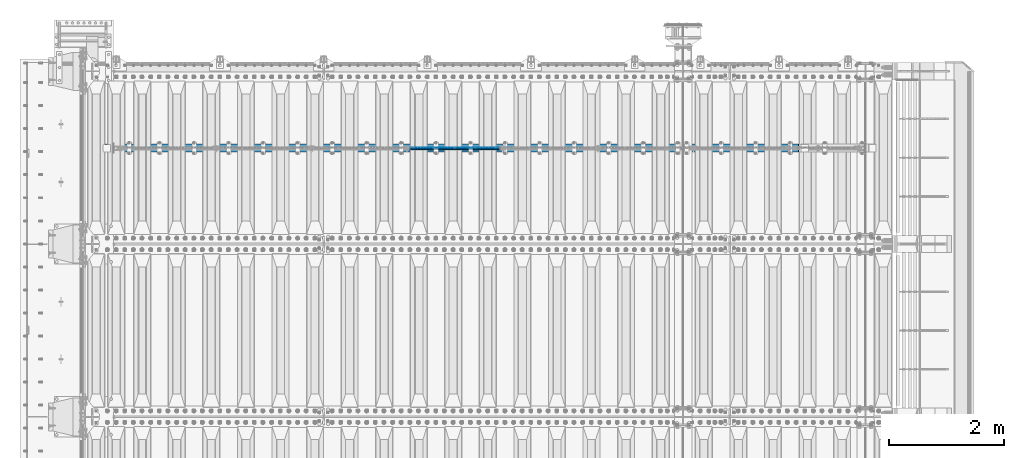
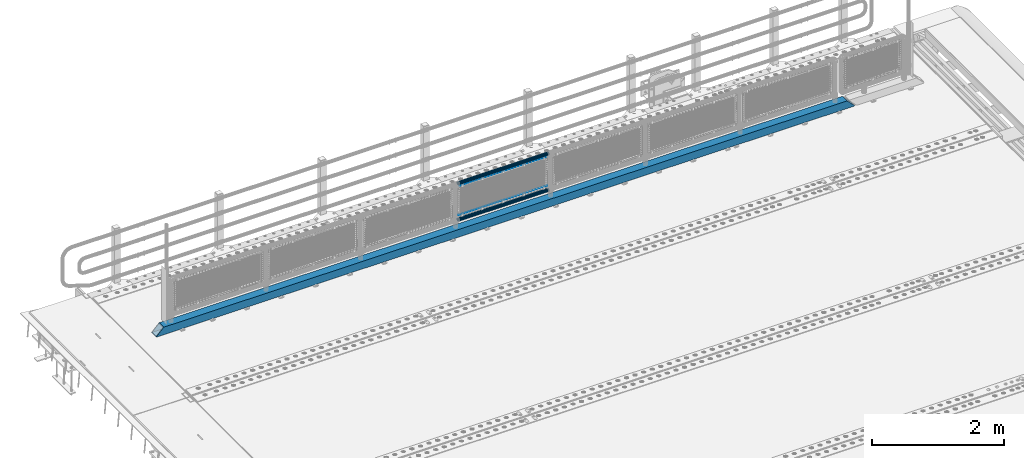
# One storey, part 118 of 240: 5 beams.
"""IFC2X3 building model written with IfcOpenShell, lengths in millimetres."""

from ifc_helpers import new_model, si_unit, frame, origin_with_axes, place, context, subcontext, project, spatial, faceted_brep, material, type_object, element, save


model = new_model("IFC2X3")

# Units and contexts
model_context = context("Model", 3, precision=1e-05, world=origin_with_axes())
body_context = subcontext(model_context, "Body", "Model", "MODEL_VIEW")
ifc_project = project(units=[si_unit("LENGTHUNIT", "METRE", prefix="MILLI"), si_unit("AREAUNIT", "SQUARE_METRE"), si_unit("VOLUMEUNIT", "CUBIC_METRE"), si_unit("MASSUNIT", "GRAM", prefix="KILO"), si_unit("TIMEUNIT", "SECOND"), si_unit("PLANEANGLEUNIT", "RADIAN"), si_unit("SOLIDANGLEUNIT", "STERADIAN"), si_unit("THERMODYNAMICTEMPERATUREUNIT", "DEGREE_CELSIUS"), si_unit("LUMINOUSINTENSITYUNIT", "LUMEN")], contexts=[model_context])

# Site, building, storey
site_placement = place(None, origin_with_axes())
site = spatial("IfcSite", under=ifc_project, at=site_placement, CompositionType="ELEMENT")
building_placement = place(site_placement, origin_with_axes())
building = spatial("IfcBuilding", under=site, at=building_placement, Name="Standard", CompositionType="ELEMENT")
storey_placement = place(building_placement, origin_with_axes())
storey = spatial("IfcBuildingStorey", under=building, at=storey_placement, Name="Undefined", CompositionType="ELEMENT", Elevation=0.0)

# Beams
ifc_material_1 = material(Name="Misc_Undefined")
beam_type_1 = type_object("IfcBeamType", Name="D3", PredefinedType="NOTDEFINED")
beam_1_placement = place(storey_placement, frame((48100.0, 34670.5, 378.02), z_axis=(0.0, 0.0, 1.0), x_axis=(1.0, 0.0, 0.0)))
element("IfcBeam", 1, at=beam_1_placement, inside=storey, type_object=beam_type_1, material=ifc_material_1, ObjectType="D3", context=body_context, shape_type="Brep", body=[
    faceted_brep([(-7.27595761418343e-12, -1.49999999999272, 0.0), (-7.27595761418343e-12, -0.749999999992724, -1.29903810567669), (1548.0, -0.75, -1.29903810567669), (1548.0, -1.5, 0.0), (0.0, 0.750000000007276, -1.29903810567669), (1548.0, 0.75, -1.29903810567669), (0.0, 1.50000000000728, 0.0), (1548.0, 1.5, 0.0), (0.0, 0.750000000007276, 1.29903810567669), (1548.0, 0.75, 1.29903810567669), (-7.27595761418343e-12, -0.749999999992724, 1.29903810567669), (1548.0, -0.75, 1.29903810567669)], [[[0, 1, 2, 3]], [[1, 4, 5, 2]], [[4, 6, 7, 5]], [[6, 8, 9, 7]], [[8, 10, 11, 9]], [[10, 0, 3, 11]], [[5, 7, 9, 11, 3, 2]], [[10, 8, 6, 4, 1, 0]]]),
])
beam_2_placement = place(storey_placement, frame((48125.0, 34670.5, 913.02), z_axis=(0.0, 0.0, 1.0), x_axis=(1.0, 0.0, 0.0)))
element("IfcBeam", 2, at=beam_2_placement, inside=storey, type_object=beam_type_1, material=ifc_material_1, ObjectType="D3", context=body_context, shape_type="Brep", body=[
    faceted_brep([(-7.27595761418343e-12, -1.49999999999272, 0.0), (-7.27595761418343e-12, -0.749999999992724, -1.29903810567669), (1498.0, -0.75, -1.29903810567669), (1498.0, -1.5, 0.0), (0.0, 0.750000000007276, -1.29903810567669), (1498.0, 0.75, -1.29903810567663), (0.0, 1.50000000000728, 0.0), (1498.0, 1.5, 0.0), (0.0, 0.750000000007276, 1.29903810567669), (1498.0, 0.75, 1.29903810567669), (-7.27595761418343e-12, -0.749999999992724, 1.29903810567669), (1498.0, -0.75, 1.29903810567669)], [[[0, 1, 2, 3]], [[1, 4, 5, 2]], [[4, 6, 7, 5]], [[6, 8, 9, 7]], [[8, 10, 11, 9]], [[10, 0, 3, 11]], [[5, 7, 9, 11, 3, 2]], [[10, 8, 6, 4, 1, 0]]]),
])
ifc_material_2 = material()
beam_type_2 = type_object("IfcBeamType", PredefinedType="NOTDEFINED")
beam_3_placement = place(storey_placement, frame((48079.85, 34664.5, 969.85), z_axis=(0.0, 0.0, 1.0), x_axis=(1.0, 0.0, 0.0)))
element("IfcBeam", 3, at=beam_3_placement, inside=storey, type_object=beam_type_2, material=ifc_material_2, context=body_context, shape_type="Brep", body=[
    faceted_brep([(0.0, -25.3499999999985, 0.0), (0.0, -23.4203461491634, 9.70102501045767), (1588.0, -23.4203461491634, 9.70102501045506), (1588.0, -25.3499999999985, 0.0), (0.0, -17.9251569030821, 17.9251569030821), (1588.0, -17.9251569030821, 17.925156903079), (0.0, -9.70102501045767, 23.4203461491634), (1588.0, -9.70102501045767, 23.4203461491611), (0.0, 0.0, 25.3499999999985), (1588.0, 0.0, 25.35), (0.0, 9.70102501045767, 23.4203461491634), (1588.0, 9.70102501045767, 23.4203461491611), (0.0, 17.9251569030821, 17.9251569030821), (1588.0, 17.9251569030821, 17.925156903079), (0.0, 23.4203461491634, 9.70102501045767), (1588.0, 23.4203461491634, 9.70102501045506), (0.0, 25.3499999999985, 0.0), (1588.0, 25.3499999999985, 0.0), (0.0, 23.4203461491634, -9.70102501045767), (1588.0, 23.4203461491634, -9.70102501045506), (0.0, 17.9251569030821, -17.9251569030821), (1588.0, 17.9251569030821, -17.925156903079), (0.0, 9.70102501045767, -23.4203461491634), (1588.0, 9.70102501045767, -23.4203461491611), (0.0, 0.0, -25.3499999999985), (1588.0, 0.0, -25.35), (0.0, -9.70102501045767, -23.4203461491634), (1588.0, -9.70102501045767, -23.4203461491611), (0.0, -17.9251569030821, -17.9251569030821), (1588.0, -17.9251569030821, -17.925156903079), (0.0, -23.4203461491634, -9.70102501045767), (1588.0, -23.4203461491634, -9.70102501045506), (0.0, -30.1500000000015, 0.0), (0.0, -27.8549679052157, -11.5379054858058), (1588.0, -27.8549679052157, -11.5379054858075), (1588.0, -30.1500000000015, 0.0), (0.0, -21.3192694527752, -21.3192694527752), (1588.0, -21.3192694527752, -21.3192694527744), (0.0, -11.5379054858058, -27.8549679052157), (1588.0, -11.5379054858058, -27.8549679052153), (0.0, 0.0, -30.1500000000015), (1588.0, 0.0, -30.15), (0.0, 11.5379054858058, -27.8549679052157), (1588.0, 11.5379054858058, -27.8549679052153), (0.0, 21.3192694527752, -21.3192694527752), (1588.0, 21.3192694527752, -21.3192694527744), (0.0, 27.8549679052157, -11.5379054858058), (1588.0, 27.8549679052157, -11.5379054858074), (0.0, 30.1500000000015, 0.0), (1588.0, 30.1500000000015, 0.0), (0.0, 27.8549679052157, 11.5379054858058), (1588.0, 27.8549679052157, 11.5379054858074), (0.0, 21.3192694527752, 21.3192694527752), (1588.0, 21.3192694527752, 21.3192694527744), (0.0, 11.5379054858058, 27.8549679052157), (1588.0, 11.5379054858058, 27.8549679052153), (0.0, 0.0, 30.1500000000015), (1588.0, 0.0, 30.15), (0.0, -11.5379054858058, 27.8549679052157), (1588.0, -11.5379054858058, 27.8549679052153), (0.0, -21.3192694527752, 21.3192694527752), (1588.0, -21.3192694527752, 21.3192694527744), (0.0, -27.8549679052157, 11.5379054858058), (1588.0, -27.8549679052157, 11.5379054858074)], [[[0, 1, 2, 3]], [[1, 4, 5, 2]], [[4, 6, 7, 5]], [[6, 8, 9, 7]], [[8, 10, 11, 9]], [[10, 12, 13, 11]], [[12, 14, 15, 13]], [[14, 16, 17, 15]], [[16, 18, 19, 17]], [[18, 20, 21, 19]], [[20, 22, 23, 21]], [[22, 24, 25, 23]], [[24, 26, 27, 25]], [[26, 28, 29, 27]], [[28, 30, 31, 29]], [[30, 0, 3, 31]], [[32, 33, 34, 35]], [[33, 36, 37, 34]], [[36, 38, 39, 37]], [[38, 40, 41, 39]], [[40, 42, 43, 41]], [[42, 44, 45, 43]], [[44, 46, 47, 45]], [[46, 48, 49, 47]], [[48, 50, 51, 49]], [[50, 52, 53, 51]], [[52, 54, 55, 53]], [[54, 56, 57, 55]], [[56, 58, 59, 57]], [[58, 60, 61, 59]], [[60, 62, 63, 61]], [[62, 32, 35, 63]], [[37, 39, 41, 43, 45, 47, 49, 51, 53, 55, 57, 59, 61, 63, 35, 34], [5, 7, 9, 11, 13, 15, 17, 19, 21, 23, 25, 27, 29, 31, 3, 2]], [[62, 60, 58, 56, 54, 52, 50, 48, 46, 44, 42, 40, 38, 36, 33, 32], [30, 28, 26, 24, 22, 20, 18, 16, 14, 12, 10, 8, 6, 4, 1, 0]]]),
])
beam_4_placement = place(storey_placement, frame((48079.85, 34664.5, 298.170000000002), z_axis=(0.0, 0.0, 1.0), x_axis=(1.0, 0.0, 0.0)))
element("IfcBeam", 4, at=beam_4_placement, inside=storey, type_object=beam_type_2, material=ifc_material_2, context=body_context, shape_type="Brep", body=[
    faceted_brep([(0.0, -25.3499999999985, 0.0), (0.0, -23.4203461491634, 9.70102501045767), (1588.0, -23.4203461491634, 9.70102501045506), (1588.0, -25.3499999999985, 0.0), (0.0, -17.9251569030821, 17.9251569030821), (1588.0, -17.9251569030821, 17.925156903079), (0.0, -9.70102501045767, 23.4203461491634), (1588.0, -9.70102501045767, 23.4203461491611), (0.0, 0.0, 25.3499999999985), (1588.0, 0.0, 25.35), (0.0, 9.70102501045767, 23.4203461491634), (1588.0, 9.70102501045767, 23.4203461491611), (0.0, 17.9251569030821, 17.9251569030821), (1588.0, 17.9251569030821, 17.925156903079), (0.0, 23.4203461491634, 9.70102501045767), (1588.0, 23.4203461491634, 9.70102501045506), (0.0, 25.3499999999985, 0.0), (1588.0, 25.3499999999985, 0.0), (0.0, 23.4203461491634, -9.70102501045767), (1588.0, 23.4203461491634, -9.70102501045506), (0.0, 17.9251569030821, -17.9251569030821), (1588.0, 17.9251569030821, -17.925156903079), (0.0, 9.70102501045767, -23.4203461491634), (1588.0, 9.70102501045767, -23.4203461491611), (0.0, 0.0, -25.3499999999985), (1588.0, 0.0, -25.35), (0.0, -9.70102501045767, -23.4203461491634), (1588.0, -9.70102501045767, -23.4203461491611), (0.0, -17.9251569030821, -17.9251569030821), (1588.0, -17.9251569030821, -17.925156903079), (0.0, -23.4203461491634, -9.70102501045767), (1588.0, -23.4203461491634, -9.70102501045506), (0.0, -30.1500000000015, 0.0), (0.0, -27.8549679052157, -11.5379054858058), (1588.0, -27.8549679052157, -11.5379054858075), (1588.0, -30.1500000000015, 0.0), (0.0, -21.3192694527752, -21.3192694527752), (1588.0, -21.3192694527752, -21.3192694527744), (0.0, -11.5379054858058, -27.8549679052157), (1588.0, -11.5379054858058, -27.8549679052153), (0.0, 0.0, -30.1500000000015), (1588.0, 0.0, -30.15), (0.0, 11.5379054858058, -27.8549679052157), (1588.0, 11.5379054858058, -27.8549679052153), (0.0, 21.3192694527752, -21.3192694527752), (1588.0, 21.3192694527752, -21.3192694527744), (0.0, 27.8549679052157, -11.5379054858058), (1588.0, 27.8549679052157, -11.5379054858074), (0.0, 30.1500000000015, 0.0), (1588.0, 30.1500000000015, 0.0), (0.0, 27.8549679052157, 11.5379054858058), (1588.0, 27.8549679052157, 11.5379054858074), (0.0, 21.3192694527752, 21.3192694527752), (1588.0, 21.3192694527752, 21.3192694527744), (0.0, 11.5379054858058, 27.8549679052157), (1588.0, 11.5379054858058, 27.8549679052153), (0.0, 0.0, 30.1500000000015), (1588.0, 0.0, 30.15), (0.0, -11.5379054858058, 27.8549679052157), (1588.0, -11.5379054858058, 27.8549679052153), (0.0, -21.3192694527752, 21.3192694527752), (1588.0, -21.3192694527752, 21.3192694527744), (0.0, -27.8549679052157, 11.5379054858058), (1588.0, -27.8549679052157, 11.5379054858074)], [[[0, 1, 2, 3]], [[1, 4, 5, 2]], [[4, 6, 7, 5]], [[6, 8, 9, 7]], [[8, 10, 11, 9]], [[10, 12, 13, 11]], [[12, 14, 15, 13]], [[14, 16, 17, 15]], [[16, 18, 19, 17]], [[18, 20, 21, 19]], [[20, 22, 23, 21]], [[22, 24, 25, 23]], [[24, 26, 27, 25]], [[26, 28, 29, 27]], [[28, 30, 31, 29]], [[30, 0, 3, 31]], [[32, 33, 34, 35]], [[33, 36, 37, 34]], [[36, 38, 39, 37]], [[38, 40, 41, 39]], [[40, 42, 43, 41]], [[42, 44, 45, 43]], [[44, 46, 47, 45]], [[46, 48, 49, 47]], [[48, 50, 51, 49]], [[50, 52, 53, 51]], [[52, 54, 55, 53]], [[54, 56, 57, 55]], [[56, 58, 59, 57]], [[58, 60, 61, 59]], [[60, 62, 63, 61]], [[62, 32, 35, 63]], [[37, 39, 41, 43, 45, 47, 49, 51, 53, 55, 57, 59, 61, 63, 35, 34], [5, 7, 9, 11, 13, 15, 17, 19, 21, 23, 25, 27, 29, 31, 3, 2]], [[62, 60, 58, 56, 54, 52, 50, 48, 46, 44, 42, 40, 38, 36, 33, 32], [30, 28, 26, 24, 22, 20, 18, 16, 14, 12, 10, 8, 6, 4, 1, 0]]]),
])
beam_type_3 = type_object("IfcBeamType", PredefinedType="NOTDEFINED")
beam_5_placement = place(storey_placement, frame((42775.0, 34664.5, 98.0199999999977), z_axis=(0.0, 0.0, 1.0), x_axis=(1.0, 0.0, 0.0)))
element("IfcBeam", 5, at=beam_5_placement, inside=storey, type_object=beam_type_3, material=ifc_material_2, context=body_context, shape_type="Brep", body=[
    faceted_brep([(0.0, -70.0, -70.0), (0.0, 70.0, -70.0), (12202.0, 70.0, -70.0), (12202.0, -70.0, -70.0), (12071.8884698478, -70.0, 70.0), (12071.8884698478, 70.0, 70.0), (130.111530936141, 70.0, 70.0), (130.111528976144, -70.0, 70.0), (12202.0, -70.0, -60.0079600980695), (0.0, -70.0, -60.0079591069104), (12081.8964362873, -60.0, 60.0), (12202.0, -60.0, -60.0), (0.0, -60.0, -60.0), (120.103562690863, -60.0, 60.0), (12081.8964362873, 60.0, 60.0), (120.10356437086, 60.0, 60.0), (12202.0, 60.0, -60.0), (0.0, 60.0, -60.0), (12202.0, 70.0, -60.0079600980695), (0.0, 70.0, -60.007961065347)], [[[0, 1, 2, 3]], [[4, 5, 6, 7]], [[0, 3, 8, 4, 7, 9]], [[10, 11, 12, 13]], [[14, 10, 13, 15]], [[16, 14, 15, 17]], [[4, 8, 11, 10, 14, 16, 18, 5]], [[11, 8, 3, 2, 18, 16]], [[17, 12, 11, 16]], [[1, 0, 9, 12, 17, 19]], [[5, 18, 2, 1, 19, 6]], [[17, 15, 13, 12, 9, 7, 6, 19]]]),
])

save(model, "model.ifc")
